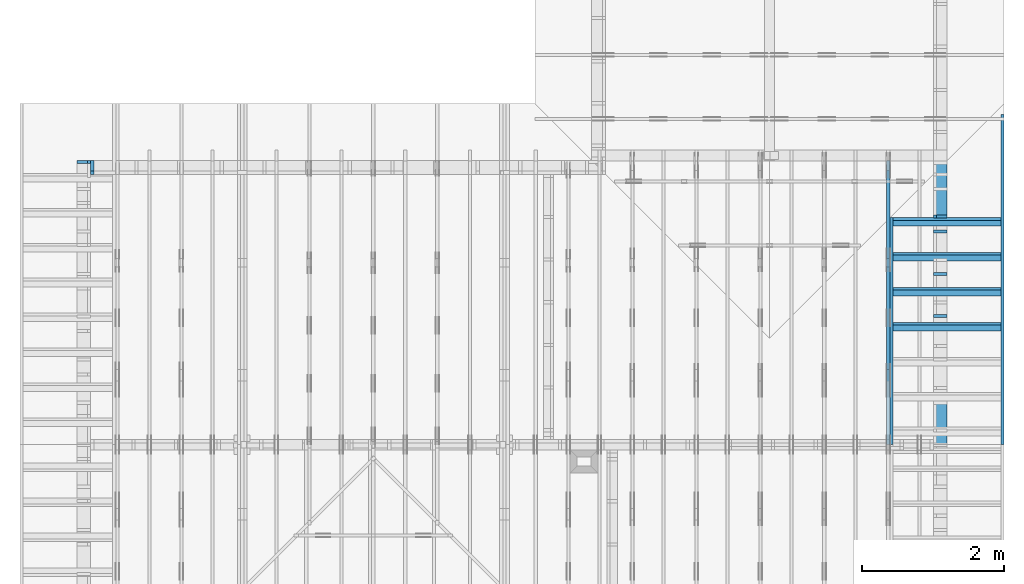
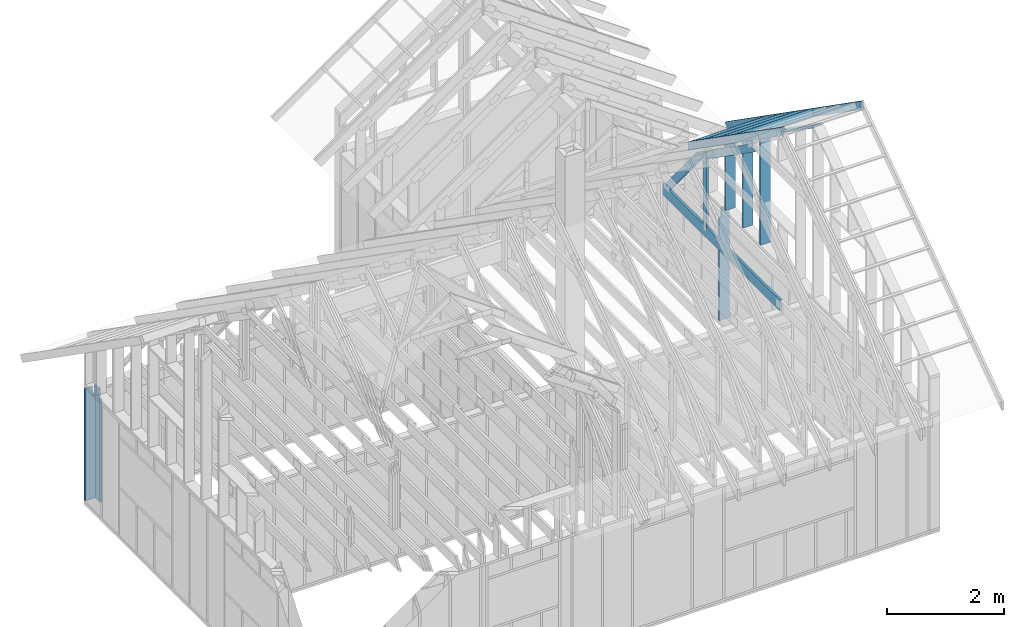
# One storey, part 28 of 70: 17 members, 6 elements without a shape of their own.
"""IFC2X3 building model written with IfcOpenShell, lengths in millimetres."""

from ifc_helpers import new_model, si_unit, frame, origin, origin_with_axes, origin_2d, place, context, project, spatial, faceted_brep, element, aggregate, save


model = new_model("IFC2X3")

# Units and contexts
model_context = context("Model", 3, precision=1e-05, world=origin())
plan_context = context("Plan", 2, precision=1e-05, world=origin_2d())
ifc_project = project(units=[si_unit("LENGTHUNIT", "METRE", prefix="MILLI"), si_unit("AREAUNIT", "SQUARE_METRE"), si_unit("VOLUMEUNIT", "CUBIC_METRE"), si_unit("SOLIDANGLEUNIT", "STERADIAN"), si_unit("PLANEANGLEUNIT", "RADIAN"), si_unit("MASSUNIT", "GRAM"), si_unit("TIMEUNIT", "SECOND"), si_unit("THERMODYNAMICTEMPERATUREUNIT", "DEGREE_CELSIUS"), si_unit("LUMINOUSINTENSITYUNIT", "LUMEN")], contexts=[model_context, plan_context])

# Site, building, storey
site_placement = place(None, origin_with_axes())
site = spatial("IfcSite", under=ifc_project, at=site_placement, CompositionType="ELEMENT")
building_placement = place(site_placement, origin_with_axes())
building = spatial("IfcBuilding", under=site, at=building_placement, Name="Layout 1", CompositionType="ELEMENT")
storey_placement = place(building_placement, origin_with_axes())
storey = spatial("IfcBuildingStorey", under=building, at=storey_placement, Name="Storey 1", CompositionType="ELEMENT", Elevation=0.0)

# Assembly, member
assembly_1_placement = place(storey_placement, frame((6999.999999999999, 8000.0, -2470.0), z_axis=(1.2246063538223773e-16, 1.0, 6.123031769111886e-17), x_axis=(-1.0, 1.2246063538223773e-16, 0.0)))
assembly_1 = element("IfcElementAssembly", 1, at=assembly_1_placement, inside=storey, Name="VE2", AssemblyPlace="FACTORY", PredefinedType="NOTDEFINED")
member_1_placement = place(assembly_1_placement, frame((7003.553390594199, 2425.0, -195.00000000000003), z_axis=(0.0, 0.0, 1.0), x_axis=(-1.836909530733566e-16, -1.0, 0.0)))
member_1 = element("IfcMember", 2, at=member_1_placement, Name="S11", context=model_context, shape_type="Brep", body=[
    faceted_brep([(0.0, 45.0, 45.00000000000003), (195.00000000186265, 45.0, 45.00000000000005), (195.00000000186265, 0.0, 45.00000000000005), (0.0, 0.0, 45.00000000000003), (195.00000000186265, -2.1311460639909362e-46, 2.842170943040401e-14), (195.00000000186265, -3.3742366240998114e-31, 45.00000000000003), (195.00000000186265, 45.0, 45.00000000000003), (195.00000000186265, 45.0, 2.842170943040401e-14), (2.7553642961003504e-15, -3.3742366240998114e-31, 45.00000000000003), (1.193991194976818e-14, -1.4621692037765842e-30, 195.00000000000003), (1.7450640541968876e-14, 45.0, 195.00000000000003), (8.266092888301048e-15, 45.0, 45.00000000000003), (2335.0, -4.2891837542628763e-13, 2.842170943040403e-14), (2335.0, -4.1697846347651946e-13, 195.00000000000003), (2.1932538056648764e-30, 1.193991194976818e-14, 195.00000000000003), (5.061354936149717e-31, 2.7553642961003504e-15, 45.00000000000003), (195.00000000186265, -3.306437155354634e-14, 45.00000000000003), (195.00000000186265, -3.5819735849646686e-14, 2.842170943040401e-14), (-1.6871183120499057e-31, 45.0, 45.00000000000003), (-7.310846018882921e-31, 44.999999999999986, 195.00000000000003), (2335.0, 44.999999999999844, 195.00000000000003), (2335.0, 44.99999999999986, 2.8421709430403998e-14), (195.00000000186265, 44.999999999999986, 2.842170943040401e-14), (195.00000000186265, 44.999999999999986, 45.00000000000003), (2335.0, 45.0, 0.0), (2335.0, 45.0, 195.00000000000003), (2335.0, 0.0, 195.00000000000003), (2335.0, 0.0, 0.0), (2335.0, 45.0, 195.00000000000003), (0.0, 45.0, 195.00000000000003), (0.0, 0.0, 195.00000000000003), (2335.0, 0.0, 195.00000000000003), (195.00000000186265, 45.0, 5.2301533330168465e-14), (2335.0, 45.0, 3.143672930479291e-13), (2335.0, 0.0, 3.143672930479291e-13), (195.00000000186265, 0.0, 5.2301533330168465e-14)], [[[0, 1, 2, 3]], [[4, 5, 6, 7]], [[8, 9, 10, 11]], [[12, 13, 14, 15, 16, 17]], [[18, 19, 20, 21, 22, 23]], [[24, 25, 26, 27]], [[28, 29, 30, 31]], [[32, 33, 34, 35]]]),
])
aggregate(assembly_1, [member_1])

assembly_2_placement = place(storey_placement, frame((-243.55339059327574, 8000.000000000001, -2470.0), z_axis=(-1.0, 1.836909530733566e-16, 6.123031769111886e-17), x_axis=(-1.836909530733566e-16, -1.0, 0.0)))
assembly_2 = element("IfcElementAssembly", 3, at=assembly_2_placement, inside=storey, Name="VE3", AssemblyPlace="FACTORY", PredefinedType="NOTDEFINED")
member_2_placement = place(assembly_2_placement, frame((45.00000000000001, 90.00000000000085, -195.00000000000003), z_axis=(0.0, 0.0, 1.0), x_axis=(6.123031769111886e-17, 1.0, 0.0)))
member_2 = element("IfcMember", 4, at=member_2_placement, Name="S11", context=model_context, shape_type="Brep", body=[
    faceted_brep([(2139.9999999981364, 45.000000000000135, 2.842170943040401e-14), (2139.9999999981364, 45.000000000000135, 45.00000000000003), (2139.9999999981364, 1.3500311979441904e-13, 45.00000000000003), (2139.9999999981364, 1.3500311979441904e-13, 2.842170943040401e-14), (2139.9999999981364, 45.000000000000135, 45.00000000000029), (2334.999999999999, 45.000000000000135, 45.00000000000031), (2334.999999999999, 1.3500311979441904e-13, 45.00000000000031), (2139.9999999981364, 1.3500311979441904e-13, 45.00000000000029), (5.684341886080802e-14, 45.00000000000015, 2.842170943040401e-14), (5.684341886080802e-14, 45.000000000000135, 195.00000000000003), (2334.999999999999, 44.99999999999999, 195.00000000000003), (2334.999999999999, 45.0, 45.00000000000003), (2139.9999999981364, 45.000000000000014, 45.00000000000003), (2139.9999999981364, 45.00000000000002, 2.8421709430404e-14), (5.684341886080801e-14, 45.00000000000001, 2.8421709430404014e-14), (2139.9999999981364, 45.00000000000001, 2.9048746914816454e-13), (2139.9999999981364, 1.3500311979441904e-13, 2.9048746914816454e-13), (5.684341886080801e-14, 1.3500311979441904e-13, 2.8421709430404014e-14), (5.684341886080802e-14, 0.0, 0.0), (1.120820287709573e-13, 9.135892724562769e-29, 195.00000000000003), (3.7656699590146706e-14, 45.000000000000014, 195.00000000000003), (-1.7581910320002584e-14, 45.000000000000014, 4.9805142853428224e-30), (2334.999999999999, -2.911598913357681e-13, 45.00000000000003), (2334.999999999999, -2.8197534368210027e-13, 195.00000000000003), (5.684341886080802e-14, 1.4694303174418721e-13, 195.00000000000003), (5.684341886080802e-14, 1.3500311979441904e-13, 2.8421709430404004e-14), (2139.9999999981364, -2.5809551978222176e-13, 2.842170943040403e-14), (2139.9999999981364, -2.553401554861214e-13, 45.00000000000003), (2334.999999999999, 45.000000000000156, 45.00000000000003), (2334.999999999999, 45.000000000000156, 195.00000000000003), (2334.999999999999, 1.5631940186722204e-13, 195.00000000000003), (2334.999999999999, 1.5631940186722204e-13, 45.00000000000003), (2334.999999999999, 45.00000000000015, 195.00000000000003), (5.684341886080802e-14, 45.00000000000015, 195.00000000000003), (5.684341886080802e-14, 7.105427357601002e-15, 195.00000000000003), (2334.999999999999, 7.105427357601002e-15, 195.00000000000003)], [[[0, 1, 2, 3]], [[4, 5, 6, 7]], [[8, 9, 10, 11, 12, 13]], [[14, 15, 16, 17]], [[18, 19, 20, 21]], [[22, 23, 24, 25, 26, 27]], [[28, 29, 30, 31]], [[32, 33, 34, 35]]]),
])
aggregate(assembly_2, [member_2])

assembly_3_placement = place(storey_placement, frame((12000.0, 0.0, -2470.0), z_axis=(1.0, -6.123031769111886e-17, 6.123031769111886e-17), x_axis=(6.123031769111886e-17, 1.0, 0.0)))
assembly_3 = element("IfcElementAssembly", 5, at=assembly_3_placement, inside=storey, Name="VE5", AssemblyPlace="FACTORY", PredefinedType="NOTDEFINED")
member_3_placement = place(assembly_3_placement, frame((7187.5000000036525, 2425.0, -195.00000000000003), z_axis=(0.0, 0.0, 1.0), x_axis=(-1.836909530733566e-16, -1.0, 0.0)))
member_3 = element("IfcMember", 6, at=member_3_placement, Name="S11", context=model_context, shape_type="Brep", body=[
    faceted_brep([(0.0, 45.0, 45.00000000000003), (195.00000000186265, 45.0, 45.00000000000005), (195.00000000186265, 0.0, 45.00000000000005), (0.0, 0.0, 45.00000000000003), (195.00000000186265, -2.1311460639909362e-46, 2.842170943040401e-14), (195.00000000186265, -3.3742366240998114e-31, 45.00000000000003), (195.00000000186265, 45.0, 45.00000000000003), (195.00000000186265, 45.0, 2.842170943040401e-14), (2.7553642961003504e-15, -3.3742366240998114e-31, 45.00000000000003), (1.193991194976818e-14, -1.4621692037765842e-30, 195.00000000000003), (1.7450640541968876e-14, 45.0, 195.00000000000003), (8.266092888301048e-15, 45.0, 45.00000000000003), (2335.0, -4.2891837542628763e-13, 2.842170943040403e-14), (2335.0, -4.1697846347651946e-13, 195.00000000000003), (2.1932538056648764e-30, 1.193991194976818e-14, 195.00000000000003), (5.061354936149717e-31, 2.7553642961003504e-15, 45.00000000000003), (195.00000000186265, -3.306437155354634e-14, 45.00000000000003), (195.00000000186265, -3.5819735849646686e-14, 2.842170943040401e-14), (-1.6871183120499057e-31, 45.0, 45.00000000000003), (-7.310846018882921e-31, 44.999999999999986, 195.00000000000003), (2335.0, 44.999999999999844, 195.00000000000003), (2335.0, 44.99999999999986, 2.8421709430403998e-14), (195.00000000186265, 44.999999999999986, 2.842170943040401e-14), (195.00000000186265, 44.999999999999986, 45.00000000000003), (2335.0, 45.0, 0.0), (2335.0, 45.0, 195.00000000000003), (2335.0, 0.0, 195.00000000000003), (2335.0, 0.0, 0.0), (2335.0, 45.0, 195.00000000000003), (0.0, 45.0, 195.00000000000003), (0.0, 0.0, 195.00000000000003), (2335.0, 0.0, 195.00000000000003), (195.00000000186265, 45.0, 5.2301533330168465e-14), (2335.0, 45.0, 3.143672930479291e-13), (2335.0, 0.0, 3.143672930479291e-13), (195.00000000186265, 0.0, 5.2301533330168465e-14)], [[[0, 1, 2, 3]], [[4, 5, 6, 7]], [[8, 9, 10, 11]], [[12, 13, 14, 15, 16, 17]], [[18, 19, 20, 21, 22, 23]], [[24, 25, 26, 27]], [[28, 29, 30, 31]], [[32, 33, 34, 35]]]),
])
aggregate(assembly_3, [member_3])

# Assembly, members
assembly_4_placement = place(storey_placement, frame((11150.0, 8000.0, -9.081170196248781e-13), z_axis=(-1.0, 1.836909530733566e-16, 6.123031769111886e-17), x_axis=(-1.836909530733566e-16, -1.0, 0.0)))
assembly_4 = element("IfcElementAssembly", 7, at=assembly_4_placement, inside=storey, Name="T3", AssemblyPlace="FACTORY", PredefinedType="TRUSS")
member_4_placement = place(assembly_4_placement, frame((3999.9999999999995, 220.0, -45.0), z_axis=(0.0, 0.0, 1.0), x_axis=(-1.0, 1.2246063538223773e-16, 0.0)))
member_4 = element("IfcMember", 8, at=member_4_placement, Name="B3", context=model_context, shape_type="Brep", body=[
    faceted_brep([(3999.9999999999995, 220.00000000000048, 45.0), (0.0, 220.00000000000048, 45.0), (0.0, 0.0, 45.0), (4000.0, 0.0, 45.0), (0.0, 220.00000000000048, 0.0), (3999.9999999999995, 220.00000000000048, 4.898425415289508e-13), (4000.0, 0.0, 4.898425415289509e-13), (0.0, 0.0, 0.0), (0.0, 0.0, 0.0), (2.755364296100349e-15, -3.3742366240998092e-31, 45.0), (2.969670408019265e-14, 220.0, 45.0), (2.69413397840923e-14, 220.0, -1.6496267940043512e-30), (4000.0, -7.347638122934264e-13, 7.457441671638533e-29), (4000.0, -7.32008447997326e-13, 45.0), (5.061354936149714e-31, 2.755364296100349e-15, 45.0), (0.0, 0.0, 0.0), (4000.0, 220.00000000000048, 5.048709793414476e-29), (4000.0, 220.00000000000048, 45.0), (4000.0, 4.831690603168681e-13, 45.0), (4000.0, 4.831690603168681e-13, 0.0), (0.0, 220.0, 0.0), (0.0, 220.0, 45.0), (3999.9999999999995, 220.00000000000065, 45.0), (3999.9999999999995, 220.00000000000065, 9.466330862652142e-30)], [[[0, 1, 2, 3]], [[4, 5, 6, 7]], [[8, 9, 10, 11]], [[12, 13, 14, 15]], [[16, 17, 18, 19]], [[20, 21, 22, 23]]]),
])
member_5_placement = place(assembly_4_placement, frame((1500.000000004151, 1635.2479181252359, -45.0), z_axis=(0.0, 0.0, 1.0), x_axis=(0.8191520442886487, 0.5735764363515361, 0.0)))
member_5 = element("IfcMember", 9, at=member_5_placement, Name="SC5", context=model_context, shape_type="Brep", body=[
    faceted_brep([(1858.470759764839, 145.00000000273417, 45.0), (101.53009304261923, 145.00000000273417, 45.0), (0.0, 4.395587893668562e-09, 45.0), (2065.5522207463405, 4.395587893668562e-09, 45.0), (101.53009304261923, 145.00000000273417, 1.2433439704416865e-14), (1858.470759764839, 145.00000000273417, 2.2758951008011226e-13), (2065.5522207463405, 4.395587893668562e-09, 2.52948837367789e-13), (0.0, 4.395587893668562e-09, 0.0), (8.6935104615022825e-16, 4.395587284942406e-09, -6.498261357111438e-32), (3.1264133420566933e-15, 4.395585704530372e-09, 45.0), (101.5300930426192, 145.00000000701368, 45.0), (101.5300930426192, 145.00000000701368, 1.9667596592082453e-30), (2065.5522207463405, -4.425913119322423e-13, 2.71000066369662e-29), (2065.5522207463405, -4.3983594763614193e-13, 45.0), (5.864129370369717e-27, 4.395590649032858e-09, 45.0), (0.0, 4.395587893668562e-09, 0.0), (1858.470759764839, 145.00000000273428, 0.0), (1858.470759764839, 145.00000000273428, 45.0), (2065.552220746341, -1.1368683772161603e-13, 45.0), (2065.552220746341, -1.1368683772161603e-13, 0.0), (101.53009304261923, 145.00000000701368, 1.5777218104420236e-30), (101.53009304261923, 145.00000000701368, 45.0), (1858.470759764839, 145.00000000273437, 45.0), (1858.470759764839, 145.00000000273437, 1.262177448353619e-29)], [[[0, 1, 2, 3]], [[4, 5, 6, 7]], [[8, 9, 10, 11]], [[12, 13, 14, 15]], [[16, 17, 18, 19]], [[20, 21, 22, 23]]]),
])
member_6_placement = place(assembly_4_placement, frame((1380.0000000018192, 1812.2602625085638, -45.0), z_axis=(0.0, 0.0, 1.0), x_axis=(-1.836909530733566e-16, -1.0, 0.0)))
member_6 = element("IfcMember", 10, at=member_6_placement, Name="R1", context=model_context, shape_type="Brep", body=[
    faceted_brep([(1592.2602625085638, 120.00000000001455, 45.0), (0.0, 120.00000000001455, 45.0), (84.02490458526881, 1.432454155292362e-11, 45.0), (1592.2602625085638, 1.432454155292362e-11, 45.0), (0.0, 120.00000000001455, 0.0), (1592.2602625085638, 120.00000000001455, 1.9498920344068735e-13), (1592.2602625085638, 1.432454155292362e-11, 1.9498920344068735e-13), (84.02490458526881, 1.432454155292362e-11, 1.0289743203443919e-14), (84.0249045852688, 1.4303225270850817e-11, 1.5777218104420236e-30), (84.02490458526881, 1.4303225270850817e-11, 45.0), (2.1316282072803006e-14, 120.00000000001435, 45.0), (2.1316282072803006e-14, 120.00000000001435, -2.3665827156630354e-30), (1592.2602625085638, -7.262347142616226e-13, 4.446758227255812e-29), (1592.2602625085638, -7.234793499655223e-13, 45.0), (84.02490458526881, 1.4288972904488156e-11, 45.0), (84.02490458526881, 1.4286217540192056e-11, 2.3465914747521543e-30), (1592.2602625085638, 120.00000000001455, 0.0), (1592.2602625085638, 120.00000000001455, 45.0), (1592.2602625085638, 0.0, 45.0), (1592.2602625085638, 0.0, 0.0), (0.0, 120.00000000001432, 0.0), (0.0, 120.00000000001432, 45.0), (1592.2602625085638, 120.00000000001458, 45.0), (1592.2602625085638, 120.00000000001458, 1.5777218104420236e-30)], [[[0, 1, 2, 3]], [[4, 5, 6, 7]], [[8, 9, 10, 11]], [[12, 13, 14, 15]], [[16, 17, 18, 19]], [[20, 21, 22, 23]]]),
])
member_7_placement = place(assembly_4_placement, frame((1323.9061318638364, 1774.1671329521819, -45.0), z_axis=(0.0, 0.0, 1.0), x_axis=(-0.6335417245359891, -0.7737085260432154, 0.0)))
member_7 = element("IfcMember", 11, at=member_7_placement, Name="W6", context=model_context, shape_type="Brep", body=[
    faceted_brep([(1889.9928508901896, 145.00000000000045, 45.0), (88.54013234780132, 145.00000000000045, 45.0), (0.0, 72.4999999998246, 45.0), (258.1329393158155, 1.0373923942097463e-12, 45.0), (1860.818453163112, 1.0373923942097463e-12, 45.0), (1949.358585509489, 72.4999999998246, 45.0), (88.54013234780132, 145.00000000000045, 1.0842680864139169e-14), (1889.9928508901896, 145.00000000000045, 2.314497253878995e-13), (1949.358585509489, 72.4999999998246, 2.387196909693122e-13), (1860.818453163112, 1.0373923942097463e-12, 2.278770101053475e-13), (258.1329393158155, 1.0373923942097463e-12, 3.161112376169938e-14), (0.0, 72.4999999998246, 0.0), (1.4210854715202004e-14, 72.49999999982458, -1.1832913578315177e-30), (1.4210854715202004e-14, 72.49999999982458, 45.0), (88.54013234780135, 145.00000000000057, 45.0), (88.54013234780135, 145.00000000000057, -7.888609052210118e-31), (258.13293931581546, 9.094947017729282e-13, 9.44327198188855e-30), (258.13293931581546, 9.094947017729282e-13, 45.0), (0.0, 72.49999999982461, 45.0), (0.0, 72.49999999982461, -8.492704648594505e-31), (1860.818453163112, -7.900766401995888e-13, 4.837664367975264e-29), (1860.818453163112, -7.873212759034885e-13, 45.0), (258.1329393158155, 9.305482405771586e-13, 45.0), (258.1329393158155, 9.277928762810583e-13, 6.710813301567046e-30), (1949.3585855094898, 72.4999999985605, 7.573064690121713e-29), (1949.3585855094898, 72.4999999985605, 45.0), (1860.8184531631127, -7.958078640513122e-13, 45.0), (1860.8184531631127, -7.958078640513122e-13, 6.310887241768094e-29), (1889.9928508901896, 145.00000000000057, 1.262177448353619e-29), (1889.9928508901896, 145.00000000000057, 45.0), (1949.358585509489, 72.49999999856152, 45.0), (1949.358585509489, 72.49999999856152, 1.262177448353619e-29), (88.54013234780132, 145.00000000000057, 0.0), (88.54013234780132, 145.00000000000057, 45.0), (1889.9928508901896, 145.00000000000045, 45.0), (1889.9928508901896, 145.00000000000045, 0.0)], [[[0, 1, 2, 3, 4, 5]], [[6, 7, 8, 9, 10, 11]], [[12, 13, 14, 15]], [[16, 17, 18, 19]], [[20, 21, 22, 23]], [[24, 25, 26, 27]], [[28, 29, 30, 31]], [[32, 33, 34, 35]]]),
])
aggregate(assembly_4, [member_4, member_5, member_6, member_7])

assembly_5_placement = place(storey_placement, frame((11805.0, 8000.000000000002, 1.1939911949768178e-14), z_axis=(-1.0, 1.836909530733566e-16, 6.123031769111886e-17), x_axis=(-1.836909530733566e-16, -1.0, 0.0)))
assembly_5 = element("IfcElementAssembly", 12, at=assembly_5_placement, inside=storey, Name="VE9", AssemblyPlace="FACTORY", PredefinedType="NOTDEFINED")
member_8_placement = place(assembly_5_placement, frame((10.000000000341004, 775.0549035178855, -195.0), z_axis=(0.0, 0.0, 1.0), x_axis=(0.8191520442889916, 0.5735764363510464, 0.0)))
member_8 = element("IfcMember", 13, at=member_8_placement, Name="P7", context=model_context, shape_type="Brep", body=[
    faceted_brep([(4902.399948377589, 45.00000000051068, 195.0), (31.509339219816525, 45.00000000051068, 195.0), (0.0, 6.384652806445956e-10, 195.0), (4870.890609157795, 6.384652806445956e-10, 195.0), (31.509339219816525, 45.00000000051068, 3.8586537013331945e-15), (4902.399948377589, 45.00000000051068, 6.003510125761689e-13), (4870.890609157795, 6.384652806445956e-10, 5.964923588748385e-13), (0.0, 6.384652806445956e-10, 0.0), (4.564754694954421e-15, 6.384620843689482e-10, -3.4120818241452144e-31), (1.4345357977250236e-14, 6.384552359168017e-10, 195.0), (31.509339219816525, 45.000000001133465, 195.0), (31.509339219816514, 45.00000000113347, 1.1338912547579851e-30), (4870.890609157795, 1.6162133115126464e-12, -9.896125452053447e-29), (4870.890609157795, 1.6281532234624146e-12, 195.0), (1.5610947564597802e-27, 6.384772205565454e-10, 195.0), (0.0, 6.384652806445956e-10, 0.0), (4902.39994837759, 45.00000000051068, 5.048709793414476e-29), (4902.39994837759, 45.00000000051068, 195.0), (4870.890609157796, -4.547473508864641e-13, 195.0), (4870.890609157796, -4.547473508864641e-13, 5.048709793414476e-29), (31.50933921981652, 45.00000000113346, -3.944304526105059e-31), (31.50933921981652, 45.000000001133444, 195.0), (4902.399948377589, 45.00000000051017, 195.0), (4902.399948377589, 45.000000000510184, -3.076557530361946e-29)], [[[0, 1, 2, 3]], [[4, 5, 6, 7]], [[8, 9, 10, 11]], [[12, 13, 14, 15]], [[16, 17, 18, 19]], [[20, 21, 22, 23]]]),
])
member_9_placement = place(assembly_5_placement, frame((977.5000000018335, 1484.0150359570107, -195.0), z_axis=(0.0, 0.0, 1.0), x_axis=(-1.836909530733566e-16, -1.0, 0.0)))
member_9 = element("IfcMember", 14, at=member_9_placement, Name="S20", context=model_context, shape_type="Brep", body=[
    faceted_brep([(1439.0150359570107, 44.999999999985675, 195.0), (0.0, 44.999999999985675, 195.0), (31.509339219424874, 0.0, 195.0), (1439.0150359570107, 0.0, 195.0), (0.0, 44.999999999985675, 0.0), (1439.0150359570107, 44.999999999985675, 1.7622269562788919e-13), (1439.0150359570107, 0.0, 1.7622269562788919e-13), (31.509339219424874, 0.0, 3.8586537012852325e-15), (31.509339219424874, 0.0, 1.9721522630525295e-31), (31.50933921942488, 7.105427357601002e-15, 195.0), (2.1316282072803006e-14, 45.000000000000014, 195.0), (1.0658141036401503e-14, 45.00000000000001, -7.888609052210118e-31), (1439.0150359570107, -2.6942417862616327e-13, 3.0419090432935184e-29), (1439.0150359570107, -2.574842666763951e-13, 195.0), (31.509339219424874, 1.0617962135108151e-15, 195.0), (31.509339219424874, -1.0878115736257363e-14, 6.660704824117978e-31), (1439.0150359570107, 44.999999999985675, 0.0), (1439.0150359570107, 44.999999999985675, 195.0), (1439.0150359570107, 2.2737367544323206e-13, 195.0), (1439.0150359570107, 2.2737367544323206e-13, 0.0), (0.0, 45.0, 0.0), (-1.0097419586828951e-28, 44.999999999999986, 195.0), (1439.0150359570107, 44.99999999998552, 195.0), (1439.0150359570107, 44.99999999998553, -8.67746995743113e-30)], [[[0, 1, 2, 3]], [[4, 5, 6, 7]], [[8, 9, 10, 11]], [[12, 13, 14, 15]], [[16, 17, 18, 19]], [[20, 21, 22, 23]]]),
])
member_10_placement = place(assembly_5_placement, frame((1577.5000000018194, 1904.1395588826927, -195.0), z_axis=(0.0, 0.0, 1.0), x_axis=(-1.836909530733566e-16, -1.0, 0.0)))
member_10 = element("IfcMember", 15, at=member_10_placement, Name="S16", context=model_context, shape_type="Brep", body=[
    faceted_brep([(1859.1395588826927, 45.0, 195.0), (0.0, 45.0, 195.0), (31.509339219424874, 1.4097167877480388e-11, 195.0), (1859.1395588826927, 1.4097167877480388e-11, 195.0), (0.0, 45.0, 0.0), (1859.1395588826927, 45.0, 2.276714116450277e-13), (1859.1395588826927, 1.4097167877480388e-11, 2.276714116450277e-13), (31.509339219424874, 1.4097167877480388e-11, 3.8586537012852325e-15), (31.509339219424877, 1.4095391520640987e-11, -1.9721522630525295e-31), (31.509339219424888, 1.4102496947998588e-11, 195.0), (2.1316282072803006e-14, 45.00000000001412, 195.0), (1.0658141036401503e-14, 45.00000000001411, -9.860761315262648e-31), (1859.1395588826927, -8.625251156015581e-13, 5.28126868448526e-29), (1859.1395588826927, -8.505852036517899e-13, 195.0), (31.509339219424874, 1.4094489415934248e-11, 195.0), (31.509339219424874, 1.408254950398448e-11, 8.950876532819729e-31), (1859.1395588826927, 45.0, 0.0), (1859.1395588826927, 45.0, 195.0), (1859.1395588826927, 0.0, 195.0), (1859.1395588826927, 0.0, 0.0), (0.0, 45.0000000000141, 0.0), (-1.0097419586828951e-28, 45.00000000001408, 195.0), (1859.1395588826929, 45.00000000000035, 195.0), (1859.1395588826929, 45.00000000000036, 2.208810534618833e-29)], [[[0, 1, 2, 3]], [[4, 5, 6, 7]], [[8, 9, 10, 11]], [[12, 13, 14, 15]], [[16, 17, 18, 19]], [[20, 21, 22, 23]]]),
])
member_11_placement = place(assembly_5_placement, frame((2167.5000000036384, 2317.262006427438, -195.0), z_axis=(0.0, 0.0, 1.0), x_axis=(-1.836909530733566e-16, -1.0, 0.0)))
member_11 = element("IfcMember", 16, at=member_11_placement, Name="S13", context=model_context, shape_type="Brep", body=[
    faceted_brep([(2272.262006427438, 45.00000000001455, 195.0), (0.0, 45.00000000001455, 195.0), (31.509339219424874, 1.4097167877480388e-11, 195.0), (2272.262006427438, 1.4097167877480388e-11, 195.0), (0.0, 45.00000000001455, 0.0), (2272.262006427438, 45.00000000001455, 2.782626490620224e-13), (2272.262006427438, 1.4097167877480388e-11, 2.782626490620224e-13), (31.509339219424874, 1.4097167877480388e-11, 3.8586537012852325e-15), (31.509339219424877, 1.4095391520640987e-11, -1.9721522630525295e-31), (31.509339219424888, 1.4102496947998588e-11, 195.0), (2.1316282072803006e-14, 45.00000000001412, 195.0), (1.0658141036401503e-14, 45.00000000001411, -9.860761315262648e-31), (2272.262006427438, -2.4921105258013396e-13, 1.5259271921619804e-29), (2272.262006427438, -2.372711406303658e-13, 195.0), (31.509339219424874, 1.4105651992708315e-11, 195.0), (31.509339219424874, 1.4093712080758547e-11, 2.115995311542737e-31), (2272.262006427438, 45.00000000001455, 0.0), (2272.262006427438, 45.00000000001455, 195.0), (2272.262006427438, 0.0, 195.0), (2272.262006427438, 0.0, 0.0), (0.0, 45.0000000000141, 0.0), (1.5777218104420236e-30, 45.00000000001408, 195.0), (2272.262006427438, 45.00000000001445, 195.0), (2272.262006427438, 45.00000000001446, -5.5220263365470826e-30)], [[[0, 1, 2, 3]], [[4, 5, 6, 7]], [[8, 9, 10, 11]], [[12, 13, 14, 15]], [[16, 17, 18, 19]], [[20, 21, 22, 23]]]),
])
aggregate(assembly_5, [member_8, member_9, member_10, member_11])

assembly_6_placement = place(storey_placement, frame((12800.0, 4000.000000000001, 3800.8301528388397), z_axis=(4.6193645199888825e-17, 0.5735764363510464, 0.8191520442889916), x_axis=(8.527720732705881e-17, 0.8191520442889916, -0.5735764363510464)))
assembly_6 = element("IfcElementAssembly", 17, at=assembly_6_placement, inside=storey, Name="gs3", AssemblyPlace="FACTORY", PredefinedType="TRUSS")
member_12_placement = place(assembly_6_placement, frame((-8.85401010751127e-14, 1560.0, -145.0000000000505), z_axis=(0.0, 0.0, 1.0), x_axis=(1.0, 0.0, 0.0)))
member_12 = element("IfcMember", 18, at=member_12_placement, Name="T5", context=model_context, shape_type="Brep", body=[
    faceted_brep([(101.53009303921266, -2.378755336729362e-13, 5.051248308518552e-11), (0.0, 0.0, 145.00000000005048), (7.105427357601002e-14, 45.0, 145.0000000000505), (101.53009303921277, 44.999999999999766, 5.049827223047032e-11), (4001.904904133262, -7.351137259491754e-13, 5.050537765782792e-11), (3900.3748110916276, -7.075851703275189e-13, 145.0000000000505), (8.027400818681166e-14, 8.878396065215313e-15, 145.0000000000505), (101.53009303921267, -1.865015955599645e-14, 5.050537765782792e-11), (101.5300930392128, 45.0, 5.051781109753192e-11), (4001.904904133262, 45.0, 5.099545347512737e-11), (4001.904904133262, 0.0, 5.099545347512737e-11), (101.53009303921267, 0.0, 5.051781109753192e-11), (4001.90490413319, 45.0, 2.2737367544323206e-13), (3900.3748110916276, 45.0, 145.0000000000507), (3900.3748110916276, 0.0, 145.0000000000507), (4001.90490413319, 0.0, 2.2737367544323206e-13), (8.85401010751127e-14, 44.99999999999999, 145.0000000000505), (3900.3748110916276, 44.99999999999975, 145.0000000000505), (4001.904904133262, 44.99999999999976, 5.050537765782792e-11), (101.5300930392128, 44.99999999999999, 5.050537765782792e-11), (3900.3748110916276, 45.0, 145.0000000000505), (8.85401010751127e-14, 45.0, 145.0000000000505), (8.85401010751127e-14, 0.0, 145.0000000000505), (3900.3748110916276, 0.0, 145.0000000000505)], [[[0, 1, 2, 3]], [[4, 5, 6, 7]], [[8, 9, 10, 11]], [[12, 13, 14, 15]], [[16, 17, 18, 19]], [[20, 21, 22, 23]]]),
])
member_13_placement = place(assembly_6_placement, frame((5672.432027765269, 45.0, -145.00000000000003), z_axis=(0.0, 0.0, 1.0), x_axis=(-1.0, 1.2246063538223773e-16, 0.0)))
member_13 = element("IfcMember", 19, at=member_13_placement, Name="T3", context=model_context, shape_type="Brep", body=[
    faceted_brep([(5570.901934726056, 45.000000000000696, 0.0), (5672.432027765269, 45.000000000000696, 145.0), (5672.432027765269, 6.963318810448982e-13, 145.0), (5570.901934726056, 6.963318810448982e-13, 0.0), (-1.0655730319954681e-46, 45.000000000000696, 2.842170943040401e-14), (-5.436270116605249e-31, 45.00000000000069, 145.00000000000003), (5672.432027765269, 45.00000000000034, 145.00000000000003), (5570.901934726056, 45.000000000000355, 2.842170943040399e-14), (0.0, 45.0, 2.842170943040401e-14), (5570.901934726056, 45.0, 7.106379000090943e-13), (5570.901934726056, 6.821210263296962e-13, 7.106379000090943e-13), (0.0, 6.821210263296962e-13, 2.842170943040401e-14), (3.4805405954966126e-30, -4.2622921279818725e-46, 5.684341886080802e-14), (8.878396065212237e-15, -1.0872540233210498e-30, 145.00000000000003), (1.4389124657412933e-14, 44.99999999999999, 145.00000000000003), (5.5107285922006985e-15, 44.99999999999999, 2.842170943040401e-14), (5672.432027765269, -3.509750230291264e-13, 145.00000000000003), (1.6308810349815748e-30, 6.909994223949084e-13, 145.00000000000003), (3.1967190959864043e-46, 6.821210263296962e-13, 2.842170943040401e-14), (5570.901934726056, -3.4120325953833926e-13, 2.842170943040407e-14), (5672.432027765269, 45.000000000000696, 145.00000000000003), (0.0, 45.000000000000696, 145.00000000000003), (0.0, 0.0, 145.00000000000003), (5672.432027765269, 0.0, 145.00000000000003)], [[[0, 1, 2, 3]], [[4, 5, 6, 7]], [[8, 9, 10, 11]], [[12, 13, 14, 15]], [[16, 17, 18, 19]], [[20, 21, 22, 23]]]),
])
member_14_placement = place(assembly_6_placement, frame((3855.3748110946763, 1560.0000000000002, -145.0), z_axis=(0.0, 0.0, 1.0), x_axis=(-1.836909530733566e-16, -1.0, 0.0)))
member_14 = element("IfcMember", 20, at=member_14_placement, Name="W1", context=model_context, shape_type="Brep", body=[
    faceted_brep([(1515.0000000000002, 45.00000000001501, 145.0), (0.0, 45.00000000001501, 145.0), (0.0, 0.0, 145.0), (1515.0000000000002, 0.0, 145.0), (0.0, 45.00000000001501, 0.0), (1515.0000000000002, 45.00000000001501, 1.8552786260409018e-13), (1515.0000000000002, 0.0, 1.8552786260409018e-13), (0.0, 0.0, 0.0), (0.0, 0.0, 0.0), (8.878396065212235e-15, -1.0872540233210496e-30, 145.0), (1.4389124657414716e-14, 45.00000000001455, 145.0), (5.51072859220248e-15, 45.00000000001455, -3.3742366241009005e-31), (1515.0000000000002, 2.9324694934699045e-11, 1.432072261147195e-29), (1515.0000000000002, 2.933357333076426e-11, 145.0), (-1.7185231427180271e-28, 8.878396065212235e-15, 145.0), (0.0, 0.0, 0.0), (1515.0000000000002, 45.00000000001501, 0.0), (1515.0000000000002, 45.00000000001501, 145.0), (1515.0000000000002, 2.955857780762017e-11, 145.0), (1515.0000000000002, 2.955857780762017e-11, 0.0), (0.0, 45.00000000001455, 0.0), (3.1554436208840472e-30, 45.000000000014545, 145.0), (1515.0000000000002, 45.00000000001512, 145.0), (1515.0000000000002, 45.000000000015135, 7.494178599599612e-30)], [[[0, 1, 2, 3]], [[4, 5, 6, 7]], [[8, 9, 10, 11]], [[12, 13, 14, 15]], [[16, 17, 18, 19]], [[20, 21, 22, 23]]]),
])
member_15_placement = place(assembly_6_placement, frame((3255.374811094691, 1560.0000000000002, -145.0), z_axis=(0.0, 0.0, 1.0), x_axis=(-1.836909530733566e-16, -1.0, 0.0)))
member_15 = element("IfcMember", 21, at=member_15_placement, Name="W1", context=model_context, shape_type="Brep", body=[
    faceted_brep([(1515.0000000000002, 45.00000000001501, 145.0), (0.0, 45.00000000001501, 145.0), (0.0, 0.0, 145.0), (1515.0000000000002, 0.0, 145.0), (0.0, 45.00000000001501, 0.0), (1515.0000000000002, 45.00000000001501, 1.8552786260409018e-13), (1515.0000000000002, 0.0, 1.8552786260409018e-13), (0.0, 0.0, 0.0), (0.0, 0.0, 0.0), (8.878396065212235e-15, -1.0872540233210496e-30, 145.0), (1.438912465741115e-14, 44.99999999998545, 145.0), (5.510728592198916e-15, 44.99999999998545, -3.374236624098718e-31), (1515.0000000000002, -2.782917939061353e-13, 4.488421971567694e-29), (1515.0000000000002, -2.6941339784092305e-13, 145.0), (1.6308810349815745e-30, 8.878396065212235e-15, 145.0), (0.0, 0.0, 0.0), (1515.0000000000002, 45.00000000001501, 0.0), (1515.0000000000002, 45.00000000001501, 145.0), (1515.0000000000002, 4.547473508864641e-13, 145.0), (1515.0000000000002, 4.547473508864641e-13, 0.0), (0.0, 44.99999999998545, 0.0), (2.0194839173657902e-28, 44.99999999998544, 145.0), (1515.0000000000002, 45.00000000001495, 145.0), (1515.0000000000002, 45.00000000001496, -3.1554436208840472e-30)], [[[0, 1, 2, 3]], [[4, 5, 6, 7]], [[8, 9, 10, 11]], [[12, 13, 14, 15]], [[16, 17, 18, 19]], [[20, 21, 22, 23]]]),
])
member_16_placement = place(assembly_6_placement, frame((2655.3748110946763, 1560.0000000000002, -145.0), z_axis=(0.0, 0.0, 1.0), x_axis=(-1.836909530733566e-16, -1.0, 0.0)))
member_16 = element("IfcMember", 22, at=member_16_placement, Name="W1", context=model_context, shape_type="Brep", body=[
    faceted_brep([(1515.0000000000002, 45.00000000002956, 145.0), (0.0, 45.00000000002956, 145.0), (0.0, 0.0, 145.0), (1515.0000000000002, 0.0, 145.0), (0.0, 45.00000000002956, 0.0), (1515.0000000000002, 45.00000000002956, 1.8552786260409018e-13), (1515.0000000000002, 0.0, 1.8552786260409018e-13), (0.0, 0.0, 0.0), (0.0, 0.0, 0.0), (8.878396065212235e-15, -1.0872540233210496e-30, 145.0), (1.4389124657412933e-14, 45.0, 145.0), (5.510728592200698e-15, 45.0, -3.3742366240998092e-31), (1515.0000000000002, 2.9324694934699045e-11, 1.432072261147195e-29), (1515.0000000000002, 2.933357333076426e-11, 145.0), (-1.7185231427180271e-28, 8.878396065212235e-15, 145.0), (0.0, 0.0, 0.0), (1515.0000000000002, 45.00000000002956, 0.0), (1515.0000000000002, 45.00000000002956, 145.0), (1515.0000000000002, 2.955857780762017e-11, 145.0), (1515.0000000000002, 2.955857780762017e-11, 0.0), (0.0, 45.0, 0.0), (2.0194839173657902e-28, 44.99999999999999, 145.0), (1515.0000000000002, 45.0000000000295, 145.0), (1515.0000000000002, 45.00000000002951, -3.1554436208840472e-30)], [[[0, 1, 2, 3]], [[4, 5, 6, 7]], [[8, 9, 10, 11]], [[12, 13, 14, 15]], [[16, 17, 18, 19]], [[20, 21, 22, 23]]]),
])
member_17_placement = place(assembly_6_placement, frame((2055.3748110946763, 1560.0000000000002, -145.0), z_axis=(0.0, 0.0, 1.0), x_axis=(-1.836909530733566e-16, -1.0, 0.0)))
member_17 = element("IfcMember", 23, at=member_17_placement, Name="W1", context=model_context, shape_type="Brep", body=[
    faceted_brep([(1515.0000000000002, 45.00000000001501, 145.0), (0.0, 45.00000000001501, 145.0), (0.0, 0.0, 145.0), (1515.0000000000002, 0.0, 145.0), (0.0, 45.00000000001501, 0.0), (1515.0000000000002, 45.00000000001501, 1.8552786260409018e-13), (1515.0000000000002, 0.0, 1.8552786260409018e-13), (0.0, 0.0, 0.0), (0.0, 0.0, 0.0), (8.878396065212235e-15, -1.0872540233210496e-30, 145.0), (1.4389124657414716e-14, 45.00000000001455, 145.0), (5.51072859220248e-15, 45.00000000001455, -3.3742366241009005e-31), (1515.0000000000002, 1.4523201570396453e-11, 2.9602471163574444e-29), (1515.0000000000002, 1.4532079966461666e-11, 145.0), (-8.511071661841057e-29, 8.878396065212235e-15, 145.0), (0.0, 0.0, 0.0), (1515.0000000000002, 45.00000000001501, 0.0), (1515.0000000000002, 45.00000000001501, 145.0), (1515.0000000000002, 1.5006662579253316e-11, 145.0), (1515.0000000000002, 1.5006662579253316e-11, 0.0), (0.0, 45.00000000001455, 0.0), (3.1554436208840472e-30, 45.000000000014545, 145.0), (1515.0000000000002, 45.00000000001512, 145.0), (1515.0000000000002, 45.000000000015135, 7.494178599599612e-30)], [[[0, 1, 2, 3]], [[4, 5, 6, 7]], [[8, 9, 10, 11]], [[12, 13, 14, 15]], [[16, 17, 18, 19]], [[20, 21, 22, 23]]]),
])
aggregate(assembly_6, [member_12, member_13, member_14, member_15, member_16, member_17])

save(model, "model.ifc")
